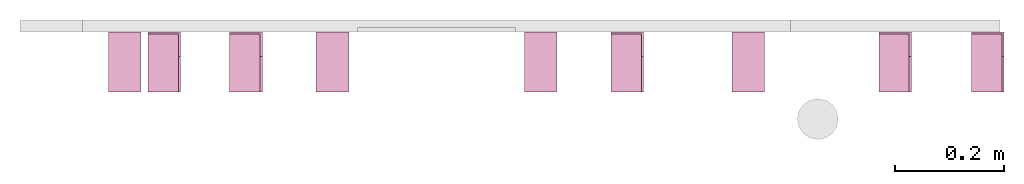
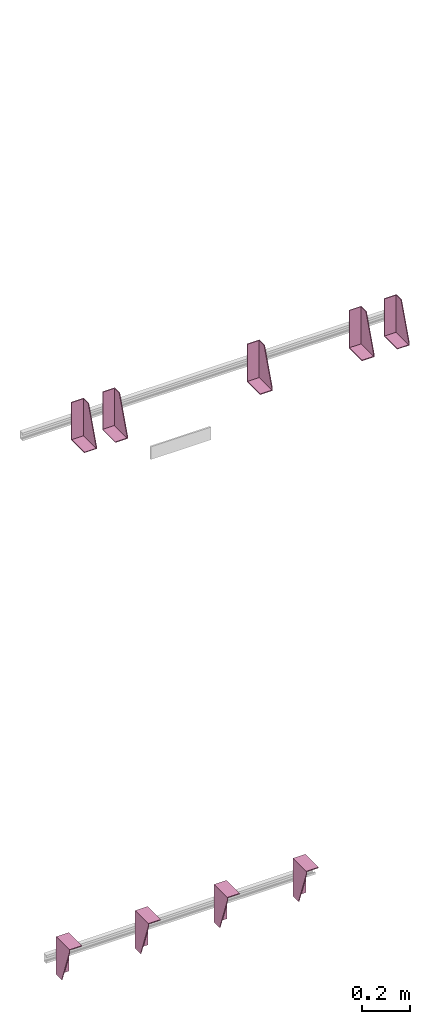
# One storey, part 3 of 3: 9 transport elements.
"""IFC4 building model written with IfcOpenShell, lengths in millimetres."""

import ifcopenshell
import ifcopenshell.guid

model = None  # the IFC model being written
_history = None  # IfcOwnerHistory: only IFC2X3 demands one
_inside = {}  # id of a spatial element -> (the spatial element, [elements in it])
_under = {}  # id of a project, library or spatial element -> (it, [spatial elements below it])
_declared = {}  # id of a project -> (the project, [libraries it declares])
_typed = {}  # id of a type object -> (the type object, [elements of that type])
_made_of = {}  # id of a material, layer set ... -> (it, [elements and type objects made of it])


def new_model(schema):
    """Start an empty IFC model of exactly this schema.

    Asked for "IFC4X3", IfcOpenShell would pick the latest addendum, in which some entities
    have other attributes; the version numbers below select the first issue.
    IFC2X3 requires an IfcOwnerHistory on every rooted entity: one is made here for all.
    """
    global model, _history
    if schema == "IFC4X3":
        model = ifcopenshell.file(schema_version=(4, 3, 0, 0))
    else:
        model = ifcopenshell.file(schema=schema)
    _inside.clear()
    _under.clear()
    _declared.clear()
    _typed.clear()
    _made_of.clear()
    _history = None
    if model.schema == "IFC2X3":
        org = make("IfcOrganization", Name="unknown")
        user = make(
            "IfcPersonAndOrganization",
            ThePerson=make("IfcPerson", FamilyName="unknown"),
            TheOrganization=org,
        )
        app = make(
            "IfcApplication",
            ApplicationDeveloper=org,
            Version="unknown",
            ApplicationFullName="unknown",
            ApplicationIdentifier="unknown",
        )
        _history = make(
            "IfcOwnerHistory",
            OwningUser=user,
            OwningApplication=app,
            ChangeAction="ADDED",
            CreationDate=0,
        )
    return model


def make(cls, **values):
    """One entity of the class cls with the attributes given. An attribute that is None is left unset."""
    return model.create_entity(
        cls, **{name: value for name, value in values.items() if value is not None}
    )


def entity(cls, *values):
    """Any entity or typed value of the class cls, its attributes in the order of the schema. None: left unset."""
    e = model.create_entity(cls)
    for i, value in enumerate(values):
        if value is not None:
            e[i] = value
    return e


def rooted(cls, **values):
    """An entity with a GlobalId (a new one), such as an element, a storey or a relation."""
    return make(cls, GlobalId=ifcopenshell.guid.new(), OwnerHistory=_history, **values)


def si_unit(unit_type, name, prefix=None):
    """IfcSIUnit, for example si_unit("LENGTHUNIT", "METRE", prefix="MILLI")."""
    return make("IfcSIUnit", UnitType=unit_type, Prefix=prefix, Name=name)


def converted_unit(unit_type, name, factor, base, dimensions=None, offset=None):
    """IfcConversionBasedUnit, such as the inch: factor (a typed value) times the base unit."""
    return make(
        "IfcConversionBasedUnit"
        if offset is None
        else "IfcConversionBasedUnitWithOffset",
        ConversionOffset=offset,
        Dimensions=None
        if dimensions is None
        else entity("IfcDimensionalExponents", *dimensions),
        UnitType=unit_type,
        Name=name,
        ConversionFactor=make(
            "IfcMeasureWithUnit", ValueComponent=factor, UnitComponent=base
        ),
    )


def assignment(units):
    """IfcUnitAssignment: the units of a project."""
    return None if units is None else make("IfcUnitAssignment", Units=units)


def point(xyz):
    """IfcCartesianPoint."""
    return None if xyz is None else make("IfcCartesianPoint", Coordinates=xyz)


def direction(xyz):
    """IfcDirection."""
    return None if xyz is None else make("IfcDirection", DirectionRatios=xyz)


def frame(location, z_axis=None, x_axis=None):
    """IfcAxis2Placement3D, a coordinate frame: its origin and axes. An axis left out is left unset."""
    return make(
        "IfcAxis2Placement3D",
        Location=point(location),
        Axis=direction(z_axis),
        RefDirection=direction(x_axis),
    )


def origin_with_axes():
    """The frame at (0, 0, 0) with the z axis (0, 0, 1) and the x axis (1, 0, 0) written out."""
    return frame((0.0, 0.0, 0.0), z_axis=(0.0, 0.0, 1.0), x_axis=(1.0, 0.0, 0.0))


def place(relative_to, where):
    """IfcLocalPlacement: puts the frame where relative to a parent placement (None: the world)."""
    return make(
        "IfcLocalPlacement", PlacementRelTo=relative_to, RelativePlacement=where
    )


def context(
    kind, dimensions, precision=None, world=None, true_north=None, identifier=None
):
    """IfcGeometricRepresentationContext, for example the 3D "Model" context."""
    return make(
        "IfcGeometricRepresentationContext",
        ContextIdentifier=identifier,
        ContextType=kind,
        CoordinateSpaceDimension=dimensions,
        Precision=precision,
        WorldCoordinateSystem=world,
        TrueNorth=true_north,
    )


def subcontext(parent, identifier, kind, view, scale=None):
    """IfcGeometricRepresentationSubContext, for example "Body" below "Model"."""
    return make(
        "IfcGeometricRepresentationSubContext",
        ContextIdentifier=identifier,
        ContextType=kind,
        ParentContext=parent,
        TargetScale=scale,
        TargetView=view,
    )


def project(units=None, contexts=None):
    """IfcProject with its units and contexts."""
    return rooted(
        "IfcProject",
        Name="project",
        RepresentationContexts=contexts,
        UnitsInContext=assignment(units),
    )


def spatial(cls, under=None, at=None, **own):
    """A site, building, storey or space (cls), placed at a placement, below another one or the project."""
    s = rooted(cls, ObjectPlacement=at, **own)
    if under is not None:
        _under.setdefault(under.id(), (under, []))[1].append(s)
    return s


def faces_of(points, faces, orient=None, outer=None):
    """IfcFace entities. A face is a list of loops; a loop is a list of indices into points, from 0.

    orient and outer hold one flag for each loop. By default every Orientation is true, the
    first loop of a face is its IfcFaceOuterBound and the others are IfcFaceBound.
    """
    made = []
    for i, loops in enumerate(faces):
        bounds = []
        for j, loop in enumerate(loops):
            is_outer = j == 0 if outer is None else outer[i][j]
            bounds.append(
                make(
                    "IfcFaceOuterBound" if is_outer else "IfcFaceBound",
                    Bound=make("IfcPolyLoop", Polygon=[points[k] for k in loop]),
                    Orientation=True if orient is None else orient[i][j],
                )
            )
        made.append(make("IfcFace", Bounds=bounds))
    return made


def faceted_brep(points, faces, orient=None, outer=None, voids=None):
    """IfcFacetedBrep: a solid bounded by flat faces; with voids (closed shells), ...WithVoids."""
    shared = [point(p) for p in points]
    hull = make("IfcClosedShell", CfsFaces=faces_of(shared, faces, orient, outer))
    if voids is None:
        return make("IfcFacetedBrep", Outer=hull)
    return make(
        "IfcFacetedBrepWithVoids",
        Outer=hull,
        Voids=[
            make(cls, CfsFaces=faces_of(shared, fs, o, b)) for cls, fs, o, b in voids
        ],
    )


def shape(context_of_items, identifier, shape_type, items):
    """IfcShapeRepresentation: the items that make up one representation, for example the "Body"."""
    return make(
        "IfcShapeRepresentation",
        ContextOfItems=context_of_items,
        RepresentationIdentifier=identifier,
        RepresentationType=shape_type,
        Items=items,
    )


def made_of(thing, what):
    """Note that an element or type object is made of a material, layer set ...; save() writes the relation."""
    if what is not None:
        _made_of.setdefault(what.id(), (what, []))[1].append(thing)
    return thing


def element(
    cls,
    number,
    at=None,
    inside=None,
    cuts=None,
    type_object=None,
    material=None,
    context=None,
    identifier="Body",
    shape_type=None,
    held_by="IfcProductDefinitionShape",
    body=None,
    shapes=None,
    **own,
):
    """One element of the class cls, such as IfcWall. Its Tag is "e" and its number.

    at: its placement. inside: the storey or other place that contains it. cuts: it is an
    opening in that element (IfcRelVoidsElement). A single representation is given by context,
    identifier, shape_type and body (its items); several are given by shapes. held_by: the class
    of the entity that holds the representations. save() writes the other relations.
    """
    e = rooted(cls, Tag="e%d" % number, ObjectPlacement=at, **own)
    if body is not None:
        shapes = [shape(context, identifier, shape_type, body)]
    if shapes is not None:
        e.Representation = make(held_by, Representations=shapes)
    if inside is not None:
        _inside.setdefault(inside.id(), (inside, []))[1].append(e)
    if cuts is not None:
        rooted(
            "IfcRelVoidsElement", RelatingBuildingElement=cuts, RelatedOpeningElement=e
        )
    if type_object is not None:
        _typed.setdefault(type_object.id(), (type_object, []))[1].append(e)
    return made_of(e, material)


def aggregate(whole, parts):
    """IfcRelAggregates: a whole, such as a stair, and the parts it consists of."""
    return rooted("IfcRelAggregates", RelatingObject=whole, RelatedObjects=parts)


def save(model, path):
    """Write the relations noted so far, then the file.

    IfcRelAggregates (storeys below a building ...), IfcRelContainedInSpatialStructure (elements
    in a storey), IfcRelDefinesByType, IfcRelAssociatesMaterial and IfcRelDeclares: one each for
    every whole, place, type object, material and project.
    """
    for whole, parts in _under.values():
        aggregate(whole, parts)
    for where, things in _inside.values():
        rooted(
            "IfcRelContainedInSpatialStructure",
            RelatedElements=things,
            RelatingStructure=where,
        )
    for kind, things in _typed.values():
        rooted("IfcRelDefinesByType", RelatedObjects=things, RelatingType=kind)
    for what, things in _made_of.values():
        rooted("IfcRelAssociatesMaterial", RelatedObjects=things, RelatingMaterial=what)
    for by, libraries in _declared.values():
        rooted("IfcRelDeclares", RelatingContext=by, RelatedDefinitions=libraries)
    model.write(path)


model = new_model("IFC4")

# Units and contexts
context_of_model = context(None, 3, precision=0.01, world=origin_with_axes())
sub_context_1 = subcontext(context_of_model, None, None, "MODEL_VIEW")
sub_context_2 = subcontext(context_of_model, None, None, "MODEL_VIEW")
sub_context_3 = subcontext(context_of_model, None, None, "MODEL_VIEW")
sub_context_4 = subcontext(context_of_model, None, None, "MODEL_VIEW")
sub_context_5 = subcontext(context_of_model, None, None, "MODEL_VIEW")
sub_context_6 = subcontext(context_of_model, None, None, "MODEL_VIEW")
sub_context_7 = subcontext(context_of_model, None, None, "MODEL_VIEW")
sub_context_8 = subcontext(context_of_model, None, None, "MODEL_VIEW")
sub_context_9 = subcontext(context_of_model, None, None, "MODEL_VIEW")
ifc_project = project(units=[converted_unit("PLANEANGLEUNIT", "degree", entity("IfcPlaneAngleMeasure", 0.017453292519943), si_unit("PLANEANGLEUNIT", "RADIAN"), dimensions=[0, 0, 0, 0, 0, 0, 0]), si_unit("LENGTHUNIT", "METRE", prefix="MILLI"), si_unit("MASSUNIT", "GRAM", prefix="KILO"), converted_unit("TIMEUNIT", "year", entity("IfcTimeMeasure", 31557600.0), si_unit("TIMEUNIT", "SECOND"), dimensions=[0, 0, 1, 0, 0, 0, 0]), si_unit("THERMODYNAMICTEMPERATUREUNIT", "DEGREE_CELSIUS"), si_unit("AREAUNIT", "SQUARE_METRE"), si_unit("FORCEUNIT", "NEWTON"), si_unit("VOLUMEUNIT", "CUBIC_METRE"), si_unit("PRESSUREUNIT", "PASCAL"), si_unit("SOLIDANGLEUNIT", "STERADIAN")], contexts=[context_of_model])

# Site, building, storey
site = spatial("IfcSite", under=ifc_project)
building = spatial("IfcBuilding", under=site, Name="Document")
placement = place(None, origin_with_axes())
storey_placement = place(placement, frame((0.0, 0.0, -21760.0), z_axis=(0.0, 0.0, 1.0), x_axis=(1.0, 0.0, 0.0)))
storey = spatial("IfcBuildingStorey", under=building, at=storey_placement, Name="P9", Elevation=-21760.0)

# Transport elements
transport_element_1_placement = place(storey_placement, frame((1777.0, 2050.0, 2580.0), z_axis=(0.0, 0.0, 1.0), x_axis=(-1.0, 0.0, 0.0)))
element("IfcTransportElement", 1, at=transport_element_1_placement, inside=storey, PredefinedType="ELEVATOR", context=sub_context_1, shape_type="Brep", body=[
    faceted_brep([(-30.0, 4.0, -93.0), (-30.0, 4.0, 97.0), (-30.0, 45.0, 97.0), (-30.0, 110.0, -82.0), (-30.0, 110.0, -93.0), (-26.0, 4.0, -93.0), (-26.0, 110.0, -93.0), (-26.0, 110.0, -82.0), (-26.0, 45.0, 97.0), (-26.0, 4.0, 97.0)], [[[0, 1, 2, 3, 4]], [[5, 6, 7, 8, 9]], [[5, 0, 4, 6]], [[6, 4, 3, 7]], [[7, 3, 2, 8]], [[8, 2, 1, 9]], [[9, 1, 0, 5]]]),
    faceted_brep([(30.0, 110.0, -93.0), (30.0, 4.0, -93.0), (30.0, 4.0, 97.0), (30.0, 0.0, 97.0), (30.0, 0.0, -97.0), (30.0, 110.0, -97.0), (-30.0, 0.0, -97.0), (-30.0, 0.0, 97.0), (-30.0, 4.0, 97.0), (-30.0, 4.0, -93.0), (-30.0, 110.0, -93.0), (-30.0, 110.0, -97.0)], [[[0, 1, 2, 3, 4, 5]], [[6, 7, 8, 9, 10, 11]], [[11, 10, 0, 5]], [[9, 8, 2, 1]], [[3, 7, 6, 4]], [[4, 6, 11, 5]], [[10, 9, 1, 0]], [[8, 7, 3, 2]]]),
])
transport_element_2_placement = place(storey_placement, frame((1607.0, 2050.0, 2580.0), z_axis=(0.0, 0.0, 1.0), x_axis=(-1.0, 0.0, 0.0)))
element("IfcTransportElement", 2, at=transport_element_2_placement, inside=storey, PredefinedType="ELEVATOR", context=sub_context_2, shape_type="Brep", body=[
    faceted_brep([(-30.0, 4.0, -93.0), (-30.0, 4.0, 97.0), (-30.0, 45.0, 97.0), (-30.0, 110.0, -82.0), (-30.0, 110.0, -93.0), (-26.0, 4.0, -93.0), (-26.0, 110.0, -93.0), (-26.0, 110.0, -82.0), (-26.0, 45.0, 97.0), (-26.0, 4.0, 97.0)], [[[0, 1, 2, 3, 4]], [[5, 6, 7, 8, 9]], [[5, 0, 4, 6]], [[6, 4, 3, 7]], [[7, 3, 2, 8]], [[8, 2, 1, 9]], [[9, 1, 0, 5]]]),
    faceted_brep([(30.0, 110.0, -93.0), (30.0, 4.0, -93.0), (30.0, 4.0, 97.0), (30.0, 0.0, 97.0), (30.0, 0.0, -97.0), (30.0, 110.0, -97.0), (-30.0, 0.0, -97.0), (-30.0, 0.0, 97.0), (-30.0, 4.0, 97.0), (-30.0, 4.0, -93.0), (-30.0, 110.0, -93.0), (-30.0, 110.0, -97.0)], [[[0, 1, 2, 3, 4, 5]], [[6, 7, 8, 9, 10, 11]], [[11, 10, 0, 5]], [[9, 8, 2, 1]], [[3, 7, 6, 4]], [[4, 6, 11, 5]], [[10, 9, 1, 0]], [[8, 7, 3, 2]]]),
])
transport_element_3_placement = place(storey_placement, frame((1115.0, 2050.0, 2580.0), z_axis=(0.0, 0.0, 1.0), x_axis=(-1.0, 0.0, 0.0)))
element("IfcTransportElement", 3, at=transport_element_3_placement, inside=storey, PredefinedType="ELEVATOR", context=sub_context_3, shape_type="Brep", body=[
    faceted_brep([(-30.0, 4.0, -93.0), (-30.0, 4.0, 97.0), (-30.0, 45.0, 97.0), (-30.0, 110.0, -82.0), (-30.0, 110.0, -93.0), (-26.0, 4.0, -93.0), (-26.0, 110.0, -93.0), (-26.0, 110.0, -82.0), (-26.0, 45.0, 97.0), (-26.0, 4.0, 97.0)], [[[0, 1, 2, 3, 4]], [[5, 6, 7, 8, 9]], [[5, 0, 4, 6]], [[6, 4, 3, 7]], [[7, 3, 2, 8]], [[8, 2, 1, 9]], [[9, 1, 0, 5]]]),
    faceted_brep([(30.0, 110.0, -93.0), (30.0, 4.0, -93.0), (30.0, 4.0, 97.0), (30.0, 0.0, 97.0), (30.0, 0.0, -97.0), (30.0, 110.0, -97.0), (-30.0, 0.0, -97.0), (-30.0, 0.0, 97.0), (-30.0, 4.0, 97.0), (-30.0, 4.0, -93.0), (-30.0, 110.0, -93.0), (-30.0, 110.0, -97.0)], [[[0, 1, 2, 3, 4, 5]], [[6, 7, 8, 9, 10, 11]], [[11, 10, 0, 5]], [[9, 8, 2, 1]], [[3, 7, 6, 4]], [[4, 6, 11, 5]], [[10, 9, 1, 0]], [[8, 7, 3, 2]]]),
])
transport_element_4_placement = place(storey_placement, frame((415.0, 2050.0, 2580.0), z_axis=(0.0, 0.0, 1.0), x_axis=(-1.0, 0.0, 0.0)))
element("IfcTransportElement", 4, at=transport_element_4_placement, inside=storey, PredefinedType="ELEVATOR", context=sub_context_4, shape_type="Brep", body=[
    faceted_brep([(30.0, 110.0, -93.0), (30.0, 4.0, -93.0), (30.0, 4.0, 97.0), (30.0, 0.0, 97.0), (30.0, 0.0, -97.0), (30.0, 110.0, -97.0), (-30.0, 0.0, -97.0), (-30.0, 0.0, 97.0), (-30.0, 4.0, 97.0), (-30.0, 4.0, -93.0), (-30.0, 110.0, -93.0), (-30.0, 110.0, -97.0)], [[[0, 1, 2, 3, 4, 5]], [[6, 7, 8, 9, 10, 11]], [[11, 10, 0, 5]], [[9, 8, 2, 1]], [[3, 7, 6, 4]], [[4, 6, 11, 5]], [[10, 9, 1, 0]], [[8, 7, 3, 2]]]),
    faceted_brep([(-30.0, 4.0, -93.0), (-30.0, 4.0, 97.0), (-30.0, 45.0, 97.0), (-30.0, 110.0, -82.0), (-30.0, 110.0, -93.0), (-26.0, 4.0, -93.0), (-26.0, 110.0, -93.0), (-26.0, 110.0, -82.0), (-26.0, 45.0, 97.0), (-26.0, 4.0, 97.0)], [[[0, 1, 2, 3, 4]], [[5, 6, 7, 8, 9]], [[5, 0, 4, 6]], [[6, 4, 3, 7]], [[7, 3, 2, 8]], [[8, 2, 1, 9]], [[9, 1, 0, 5]]]),
])
transport_element_5_placement = place(storey_placement, frame((265.0, 2050.0, 2580.0), z_axis=(0.0, 0.0, 1.0), x_axis=(-1.0, 0.0, 0.0)))
element("IfcTransportElement", 5, at=transport_element_5_placement, inside=storey, PredefinedType="ELEVATOR", context=sub_context_5, shape_type="Brep", body=[
    faceted_brep([(30.0, 110.0, -93.0), (30.0, 4.0, -93.0), (30.0, 4.0, 97.0), (30.0, 0.0, 97.0), (30.0, 0.0, -97.0), (30.0, 110.0, -97.0), (-30.0, 0.0, -97.0), (-30.0, 0.0, 97.0), (-30.0, 4.0, 97.0), (-30.0, 4.0, -93.0), (-30.0, 110.0, -93.0), (-30.0, 110.0, -97.0)], [[[0, 1, 2, 3, 4, 5]], [[6, 7, 8, 9, 10, 11]], [[11, 10, 0, 5]], [[9, 8, 2, 1]], [[3, 7, 6, 4]], [[4, 6, 11, 5]], [[10, 9, 1, 0]], [[8, 7, 3, 2]]]),
    faceted_brep([(-30.0, 4.0, -93.0), (-30.0, 4.0, 97.0), (-30.0, 45.0, 97.0), (-30.0, 110.0, -82.0), (-30.0, 110.0, -93.0), (-26.0, 4.0, -93.0), (-26.0, 110.0, -93.0), (-26.0, 110.0, -82.0), (-26.0, 45.0, 97.0), (-26.0, 4.0, 97.0)], [[[0, 1, 2, 3, 4]], [[5, 6, 7, 8, 9]], [[5, 0, 4, 6]], [[6, 4, 3, 7]], [[7, 3, 2, 8]], [[8, 2, 1, 9]], [[9, 1, 0, 5]]]),
])
transport_element_6_placement = place(storey_placement, frame((192.5, 2050.0, -30.0), z_axis=(0.0, 0.0, -1.0), x_axis=(1.0, 0.0, 0.0)))
element("IfcTransportElement", 6, at=transport_element_6_placement, inside=storey, PredefinedType="ELEVATOR", context=sub_context_6, shape_type="Brep", body=[
    faceted_brep([(-30.0, 4.0, 4.0), (-30.0, 110.0, 4.0), (-30.0, 110.0, 0.0), (-30.0, 0.0, 0.0), (-30.0, 0.0, 194.0), (-30.0, 4.0, 194.0), (30.0, 0.0, 194.0), (30.0, 0.0, 0.0), (30.0, 110.0, 0.0), (30.0, 110.0, 4.0), (30.0, 4.0, 4.0), (30.0, 4.0, 194.0)], [[[0, 1, 2, 3, 4, 5]], [[6, 7, 8, 9, 10, 11]], [[11, 10, 0, 5]], [[3, 7, 6, 4]], [[9, 8, 2, 1]], [[4, 6, 11, 5]], [[0, 10, 9, 1]], [[8, 7, 3, 2]]]),
    faceted_brep([(-30.0, 4.0, 4.0), (-30.0, 4.0, 194.0), (-30.0, 45.0, 194.0), (-30.0, 110.0, 15.0), (-30.0, 110.0, 4.0), (-26.0, 4.0, 4.0), (-26.0, 110.0, 4.0), (-26.0, 110.0, 15.0), (-26.0, 45.0, 194.0), (-26.0, 4.0, 194.0)], [[[0, 1, 2, 3, 4]], [[5, 6, 7, 8, 9]], [[5, 0, 4, 6]], [[6, 4, 3, 7]], [[7, 3, 2, 8]], [[8, 2, 1, 9]], [[9, 1, 0, 5]]]),
])
transport_element_7_placement = place(storey_placement, frame((573.84, 2050.0, -30.0), z_axis=(0.0, 0.0, -1.0), x_axis=(1.0, 0.0, 0.0)))
element("IfcTransportElement", 7, at=transport_element_7_placement, inside=storey, PredefinedType="ELEVATOR", context=sub_context_7, shape_type="Brep", body=[
    faceted_brep([(-29.999973144531282, 4.0, 4.0), (-29.999973144531282, 110.0, 4.0), (-29.999973144531282, 110.0, 0.0), (-29.999973144531282, 0.0, 0.0), (-29.999973144531282, 0.0, 194.0), (-29.999973144531282, 4.0, 194.0), (30.000026855468718, 0.0, 194.0), (30.000026855468718, 0.0, 0.0), (30.000026855468718, 110.0, 0.0), (30.000026855468718, 110.0, 4.0), (30.000026855468718, 4.0, 4.0), (30.000026855468718, 4.0, 194.0)], [[[0, 1, 2, 3, 4, 5]], [[6, 7, 8, 9, 10, 11]], [[11, 10, 0, 5]], [[3, 7, 6, 4]], [[9, 8, 2, 1]], [[4, 6, 11, 5]], [[0, 10, 9, 1]], [[8, 7, 3, 2]]]),
    faceted_brep([(-29.999973144531282, 4.0, 4.0), (-29.999973144531282, 4.0, 194.0), (-29.999973144531282, 45.0, 194.0), (-29.999973144531282, 110.0, 15.0), (-29.999973144531282, 110.0, 4.0), (-25.999973144531282, 4.0, 4.0), (-25.999973144531282, 110.0, 4.0), (-25.999973144531282, 110.0, 15.0), (-25.999973144531282, 45.0, 194.0), (-25.999973144531282, 4.0, 194.0)], [[[0, 1, 2, 3, 4]], [[5, 6, 7, 8, 9]], [[5, 0, 4, 6]], [[6, 4, 3, 7]], [[7, 3, 2, 8]], [[8, 2, 1, 9]], [[9, 1, 0, 5]]]),
])
transport_element_8_placement = place(storey_placement, frame((956.16, 2050.0, -30.0), z_axis=(0.0, 0.0, -1.0), x_axis=(1.0, 0.0, 0.0)))
element("IfcTransportElement", 8, at=transport_element_8_placement, inside=storey, PredefinedType="ELEVATOR", context=sub_context_8, shape_type="Brep", body=[
    faceted_brep([(-30.000026855468718, 4.0, 4.0), (-30.000026855468718, 4.0, 194.0), (-30.000026855468718, 45.0, 194.0), (-30.000026855468718, 110.0, 15.0), (-30.000026855468718, 110.0, 4.0), (-26.000026855468718, 4.0, 4.0), (-26.000026855468718, 110.0, 4.0), (-26.000026855468718, 110.0, 15.0), (-26.000026855468718, 45.0, 194.0), (-26.000026855468718, 4.0, 194.0)], [[[0, 1, 2, 3, 4]], [[5, 6, 7, 8, 9]], [[5, 0, 4, 6]], [[6, 4, 3, 7]], [[7, 3, 2, 8]], [[8, 2, 1, 9]], [[9, 1, 0, 5]]]),
    faceted_brep([(-30.000026855468718, 4.0, 4.0), (-30.000026855468718, 110.0, 4.0), (-30.000026855468718, 110.0, 0.0), (-30.000026855468718, 0.0, 0.0), (-30.000026855468718, 0.0, 194.0), (-30.000026855468718, 4.0, 194.0), (29.999973144531282, 0.0, 194.0), (29.999973144531282, 0.0, 0.0), (29.999973144531282, 110.0, 0.0), (29.999973144531282, 110.0, 4.0), (29.999973144531282, 4.0, 4.0), (29.999973144531282, 4.0, 194.0)], [[[0, 1, 2, 3, 4, 5]], [[6, 7, 8, 9, 10, 11]], [[11, 10, 0, 5]], [[3, 7, 6, 4]], [[9, 8, 2, 1]], [[4, 6, 11, 5]], [[0, 10, 9, 1]], [[8, 7, 3, 2]]]),
])
transport_element_9_placement = place(storey_placement, frame((1337.5, 2050.0, -30.0), z_axis=(0.0, 0.0, -1.0), x_axis=(1.0, 0.0, 0.0)))
element("IfcTransportElement", 9, at=transport_element_9_placement, inside=storey, PredefinedType="ELEVATOR", context=sub_context_9, shape_type="Brep", body=[
    faceted_brep([(-30.0, 4.0, 4.0), (-30.0, 110.0, 4.0), (-30.0, 110.0, 0.0), (-30.0, 0.0, 0.0), (-30.0, 0.0, 194.0), (-30.0, 4.0, 194.0), (30.0, 0.0, 194.0), (30.0, 0.0, 0.0), (30.0, 110.0, 0.0), (30.0, 110.0, 4.0), (30.0, 4.0, 4.0), (30.0, 4.0, 194.0)], [[[0, 1, 2, 3, 4, 5]], [[6, 7, 8, 9, 10, 11]], [[11, 10, 0, 5]], [[3, 7, 6, 4]], [[9, 8, 2, 1]], [[4, 6, 11, 5]], [[0, 10, 9, 1]], [[8, 7, 3, 2]]]),
    faceted_brep([(-30.0, 4.0, 4.0), (-30.0, 4.0, 194.0), (-30.0, 45.0, 194.0), (-30.0, 110.0, 15.0), (-30.0, 110.0, 4.0), (-26.0, 4.0, 4.0), (-26.0, 110.0, 4.0), (-26.0, 110.0, 15.0), (-26.0, 45.0, 194.0), (-26.0, 4.0, 194.0)], [[[0, 1, 2, 3, 4]], [[5, 6, 7, 8, 9]], [[5, 0, 4, 6]], [[6, 4, 3, 7]], [[7, 3, 2, 8]], [[8, 2, 1, 9]], [[9, 1, 0, 5]]]),
])

save(model, "model.ifc")
